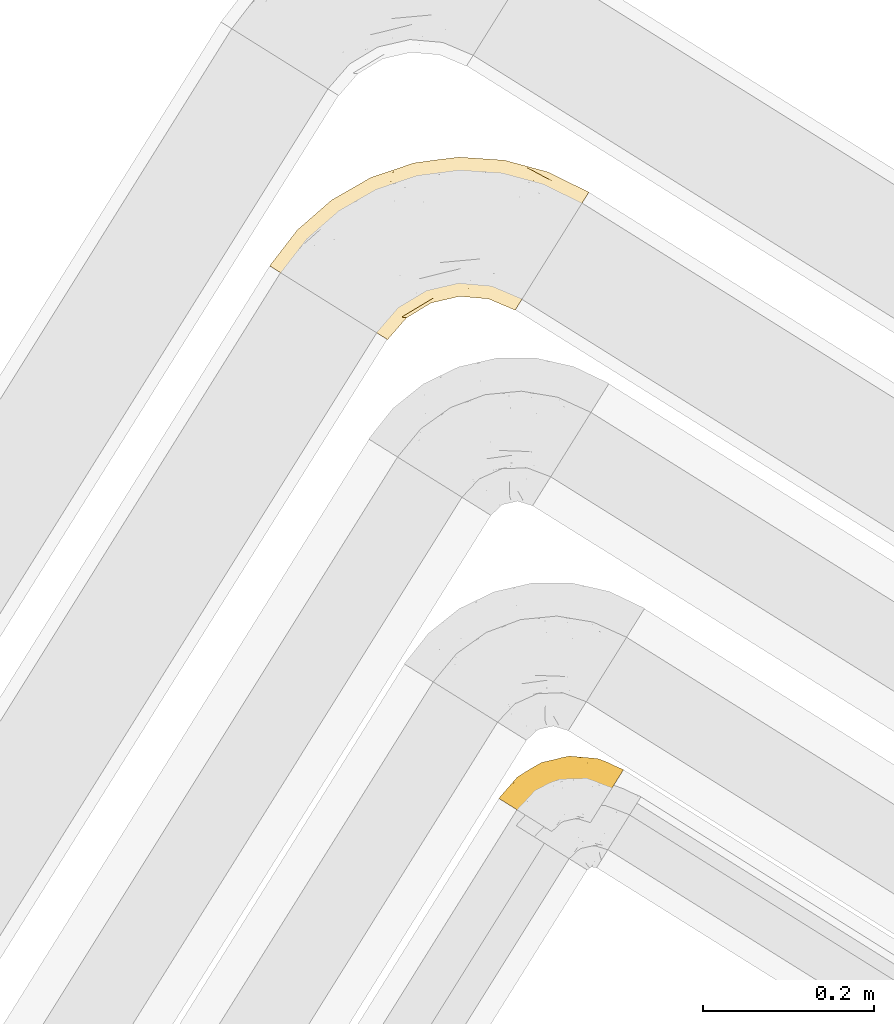
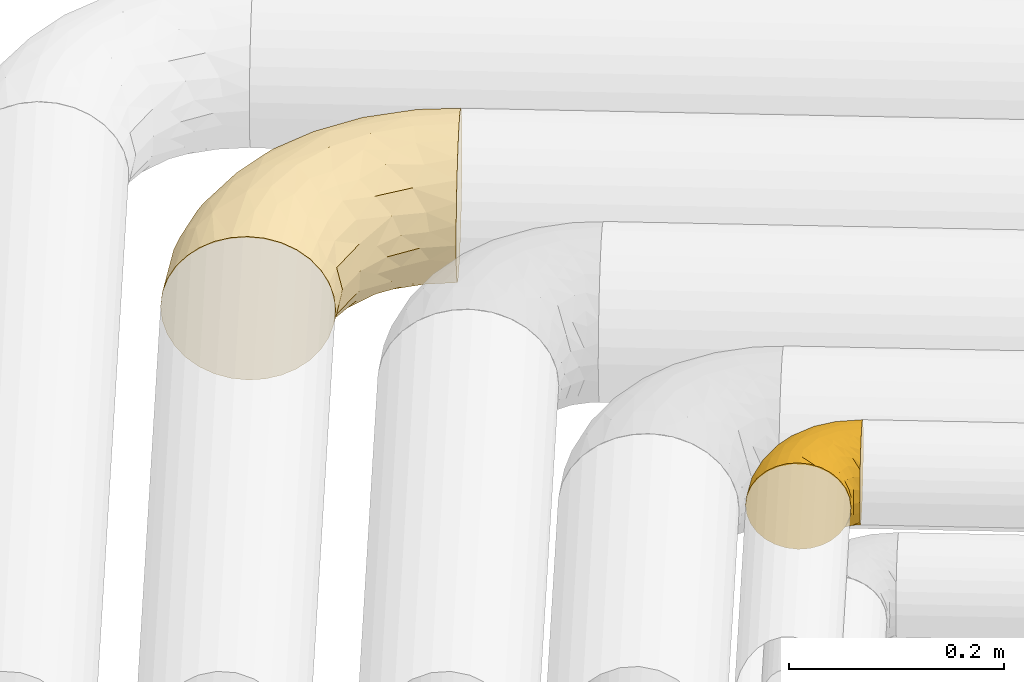
# One storey, part 25 of 93: 2 coverings.
"""IFC2X3 building model written with IfcOpenShell, lengths in millimetres."""

from ifc_helpers import new_model, entity, si_unit, converted_unit, derived_unit, direction, frame, origin, place, context, subcontext, project, spatial, faceted_brep, element, save


model = new_model("IFC2X3")

# Units and contexts
model_context = context("Model", 3, precision=0.01, world=origin(), true_north=direction((6.12303176911189e-17, 1.0)))
body_context = subcontext(model_context, "Body", "Model", "MODEL_VIEW")
ifc_project = project(units=[si_unit("LENGTHUNIT", "METRE", prefix="MILLI"), si_unit("AREAUNIT", "SQUARE_METRE"), si_unit("VOLUMEUNIT", "CUBIC_METRE"), converted_unit("PLANEANGLEUNIT", "DEGREE", entity("IfcRatioMeasure", 0.0174532925199433), si_unit("PLANEANGLEUNIT", "RADIAN"), dimensions=[0, 0, 0, 0, 0, 0, 0]), si_unit("MASSUNIT", "GRAM", prefix="KILO"), derived_unit("MASSDENSITYUNIT", [(si_unit("MASSUNIT", "GRAM", prefix="KILO"), 1), (si_unit("LENGTHUNIT", "METRE"), -3)]), derived_unit("MOMENTOFINERTIAUNIT", [(si_unit("LENGTHUNIT", "METRE"), 4)]), si_unit("TIMEUNIT", "SECOND"), si_unit("FREQUENCYUNIT", "HERTZ"), si_unit("THERMODYNAMICTEMPERATUREUNIT", "DEGREE_CELSIUS"), derived_unit("THERMALTRANSMITTANCEUNIT", [(si_unit("MASSUNIT", "GRAM", prefix="KILO"), 1), (si_unit("THERMODYNAMICTEMPERATUREUNIT", "KELVIN"), -1), (si_unit("TIMEUNIT", "SECOND"), -3)]), derived_unit("VOLUMETRICFLOWRATEUNIT", [(si_unit("LENGTHUNIT", "METRE"), 3), (si_unit("TIMEUNIT", "SECOND"), -1)]), derived_unit("MASSFLOWRATEUNIT", [(si_unit("MASSUNIT", "GRAM", prefix="KILO"), 1), (si_unit("TIMEUNIT", "SECOND"), -1)]), derived_unit("ROTATIONALFREQUENCYUNIT", [(si_unit("TIMEUNIT", "SECOND"), -1)]), si_unit("ELECTRICCURRENTUNIT", "AMPERE"), si_unit("ELECTRICVOLTAGEUNIT", "VOLT"), si_unit("POWERUNIT", "WATT"), si_unit("FORCEUNIT", "NEWTON", prefix="KILO"), si_unit("ILLUMINANCEUNIT", "LUX"), si_unit("LUMINOUSFLUXUNIT", "LUMEN"), si_unit("LUMINOUSINTENSITYUNIT", "CANDELA"), derived_unit("USERDEFINED", [(si_unit("MASSUNIT", "GRAM", prefix="KILO"), -1), (si_unit("LENGTHUNIT", "METRE"), -2), (si_unit("TIMEUNIT", "SECOND"), 3), (si_unit("LUMINOUSFLUXUNIT", "LUMEN"), 1)]), derived_unit("LINEARVELOCITYUNIT", [(si_unit("LENGTHUNIT", "METRE"), 1), (si_unit("TIMEUNIT", "SECOND"), -1)]), si_unit("PRESSUREUNIT", "PASCAL"), derived_unit("USERDEFINED", [(si_unit("LENGTHUNIT", "METRE"), -2), (si_unit("MASSUNIT", "GRAM", prefix="KILO"), 1), (si_unit("TIMEUNIT", "SECOND"), -2)]), derived_unit("LINEARFORCEUNIT", [(si_unit("MASSUNIT", "GRAM", prefix="KILO"), 1), (si_unit("LENGTHUNIT", "METRE"), 1), (si_unit("TIMEUNIT", "SECOND"), -2), (si_unit("LENGTHUNIT", "METRE"), -1)]), derived_unit("PLANARFORCEUNIT", [(si_unit("MASSUNIT", "GRAM", prefix="KILO"), 1), (si_unit("LENGTHUNIT", "METRE"), 1), (si_unit("TIMEUNIT", "SECOND"), -2), (si_unit("LENGTHUNIT", "METRE"), -2)])], contexts=[model_context])

# Site, building, storey
site_placement = place(None, origin())
site = spatial("IfcSite", under=ifc_project, at=site_placement, CompositionType="ELEMENT")
building_placement = place(site_placement, origin())
building = spatial("IfcBuilding", under=site, at=building_placement, CompositionType="ELEMENT")
storey_placement = place(building_placement, frame((0.0, 0.0, -4200.0)))
storey = spatial("IfcBuildingStorey", under=building, at=storey_placement, CompositionType="ELEMENT", Elevation=-4200.0)

# Coverings
covering_1_placement = place(storey_placement, frame((15873.6, 11387.06, 2916.9)))
element("IfcCovering", 1, at=covering_1_placement, inside=storey, Name=":ADSK_", ObjectType=":ADSK_", PredefinedType="INSULATION", context=body_context, shape_type="Brep", body=[
    faceted_brep([(44.26, 61.31, 158.39), (32.31, 68.78, 150.86), (21.84, 75.32, 140.72), (13.24, 80.69, 128.37), (6.86, 84.68, 114.28), (2.92, 87.14, 98.99), (1.6, 87.97, 83.1), (2.92, 87.14, 67.2), (6.86, 84.68, 51.91), (13.24, 80.69, 37.82), (21.84, 75.32, 25.47), (32.31, 68.78, 15.33), (44.26, 61.31, 7.8), (57.23, 53.21, 3.16), (70.71, 44.78, 1.6), (84.2, 36.36, 3.16), (97.16, 28.26, 7.8), (109.11, 20.79, 15.33), (119.58, 14.24, 25.47), (128.18, 8.87, 37.82), (134.57, 4.88, 51.91), (138.5, 2.43, 67.2), (139.83, 1.6, 83.1), (138.5, 2.43, 99.0), (134.57, 4.88, 114.28), (128.18, 8.87, 128.37), (119.58, 14.25, 140.72), (109.11, 20.79, 150.86), (97.16, 28.26, 158.39), (84.19, 36.36, 163.03), (70.71, 44.78, 164.6), (57.23, 53.21, 163.03), (290.81, 38.47, 62.0), (295.12, 45.37, 42.35), (301.99, 56.36, 25.47), (310.93, 70.67, 12.51), (321.35, 87.34, 4.37), (332.52, 105.23, 1.6), (343.7, 123.12, 4.37), (354.12, 139.79, 12.51), (363.06, 154.1, 25.47), (369.93, 165.08, 42.35), (374.24, 171.99, 62.0), (375.71, 174.34, 83.1), (374.24, 171.99, 104.19), (369.93, 165.08, 123.85), (363.06, 154.1, 140.72), (354.12, 139.79, 153.68), (343.7, 123.12, 161.82), (332.52, 105.23, 164.6), (321.35, 87.34, 161.82), (310.93, 70.67, 153.68), (301.99, 56.36, 140.72), (295.12, 45.37, 123.85), (290.81, 38.47, 104.19), (289.34, 36.11, 83.1), (303.99, 202.82, 104.67), (328.03, 197.99, 83.1), (276.65, 211.88, 83.1), (262.59, 196.89, 132.71), (202.71, 200.08, 128.57), (225.88, 192.07, 140.31), (143.86, 187.34, 127.0), (200.1, 208.43, 111.93), (145.82, 197.72, 107.33), (197.35, 212.28, 96.47), (69.76, 109.64, 153.13), (252.54, 206.3, 119.3), (247.03, 213.11, 101.32), (128.84, 166.78, 142.92), (85.14, 141.17, 142.61), (110.31, 143.75, 151.87), (294.95, 142.4, 162.56), (252.64, 132.96, 164.6), (294.15, 123.59, 164.6), (223.55, 215.47, 83.1), (82.79, 161.59, 117.97), (46.8, 130.78, 119.64), (84.59, 153.3, 131.15), (170.77, 208.64, 83.1), (120.33, 191.64, 83.1), (293.96, 160.74, 156.52), (274.17, 184.31, 144.21), (323.37, 167.6, 146.25), (311.25, 187.83, 130.43), (97.16, 78.11, 164.6), (108.65, 112.08, 162.51), (224.85, 161.05, 159.97), (217.01, 178.3, 151.26), (158.57, 167.13, 151.21), (329.49, 189.16, 117.68), (141.96, 146.57, 158.25), (152.15, 133.89, 163.04), (42.35, 134.23, 105.24), (83.84, 169.39, 100.78), (50.75, 106.99, 144.52), (176.4, 184.25, 141.87), (49.69, 122.0, 132.77), (74.18, 165.13, 83.1), (34.09, 130.13, 83.1), (130.35, 104.72, 164.6), (168.64, 123.28, 164.6), (210.1, 132.85, 164.6), (280.75, 80.9, 151.23), (261.7, 70.1, 137.69), (284.47, 102.8, 161.34), (164.81, 58.87, 141.27), (141.93, 38.59, 138.72), (163.98, 44.73, 127.05), (193.38, 50.32, 109.71), (162.1, 27.21, 83.1), (191.2, 44.7, 83.1), (235.46, 61.6, 120.43), (224.45, 74.35, 138.75), (196.71, 61.76, 129.2), (169.09, 101.3, 161.91), (144.64, 87.13, 161.43), (169.1, 84.21, 155.97), (235.91, 116.0, 162.57), (195.15, 103.02, 160.03), (216.01, 89.43, 151.82), (267.74, 54.35, 117.14), (156.27, 27.97, 109.48), (126.24, 38.95, 148.92), (143.8, 61.02, 151.93), (247.37, 94.66, 154.85), (267.44, 48.23, 98.92), (240.45, 54.25, 100.98), (224.27, 52.33, 83.1), (258.09, 49.38, 83.1), (189.58, 75.03, 145.5), (119.33, 55.41, 158.16), (121.71, 78.58, 162.97), (101.82, 57.56, 162.71), (213.63, 52.6, 98.76), (260.19, 105.07, 160.15), (144.74, 26.03, 124.12), (192.15, 88.67, 154.06), (247.38, 94.66, 11.34), (261.7, 70.1, 28.5), (224.45, 74.35, 27.44), (216.01, 89.42, 14.37), (267.44, 48.23, 67.27), (240.45, 54.25, 65.22), (163.98, 44.73, 39.14), (164.81, 58.88, 24.93), (196.71, 61.76, 36.99), (101.83, 57.56, 3.48), (193.38, 50.32, 56.48), (280.75, 80.9, 14.96), (284.47, 102.8, 4.85), (144.74, 26.03, 42.07), (141.93, 38.59, 27.47), (235.46, 61.6, 45.76), (213.63, 52.6, 67.43), (121.71, 78.58, 3.22), (119.33, 55.41, 8.03), (294.15, 123.59, 1.6), (267.74, 54.35, 49.05), (126.24, 38.95, 17.27), (156.27, 27.97, 56.71), (260.67, 116.21, 3.08), (235.91, 116.0, 3.62), (130.35, 104.72, 1.6), (168.64, 123.28, 1.6), (144.64, 87.13, 4.76), (210.1, 132.85, 1.6), (252.64, 132.96, 1.6), (189.59, 75.03, 20.69), (195.15, 103.02, 6.16), (143.8, 61.02, 14.26), (169.1, 84.21, 10.22), (169.09, 101.3, 4.28), (97.16, 78.11, 1.6), (192.03, 88.24, 12.35), (311.25, 187.83, 35.76), (85.14, 141.17, 23.58), (84.56, 153.27, 35.03), (125.1, 175.77, 34.03), (35.39, 118.57, 46.35), (268.93, 149.08, 3.68), (220.27, 149.61, 3.15), (223.86, 165.48, 7.94), (176.4, 184.25, 24.32), (180.5, 199.06, 41.48), (143.01, 142.16, 6.22), (109.58, 108.16, 2.91), (203.66, 209.98, 57.48), (281.97, 165.41, 10.43), (267.58, 195.86, 33.0), (274.17, 184.31, 21.98), (226.44, 194.19, 28.1), (296.9, 199.45, 47.91), (50.75, 106.99, 21.67), (145.82, 197.72, 58.86), (76.79, 118.16, 13.93), (252.54, 206.3, 46.89), (252.6, 212.26, 62.93), (323.37, 167.6, 19.94), (303.99, 202.82, 61.52), (126.98, 154.29, 15.08), (87.45, 107.86, 6.68), (83.84, 169.39, 65.41), (218.36, 180.9, 16.65), (174.99, 165.92, 11.53), (42.35, 134.23, 60.95), (49.69, 122.0, 33.42), (82.8, 161.59, 48.22)], [[[0, 1, 2, 3, 4, 5, 6, 7, 8, 9, 10, 11, 12, 13, 14, 15, 16, 17, 18, 19, 20, 21, 22, 23, 24, 25, 26, 27, 28, 29, 30, 31]], [[32, 33, 34, 35, 36, 37, 38, 39, 40, 41, 42, 43, 44, 45, 46, 47, 48, 49, 50, 51, 52, 53, 54, 55]], [[56, 57, 58]], [[57, 44, 43]], [[59, 60, 61]], [[62, 63, 64]], [[63, 65, 64]], [[1, 0, 66]], [[67, 68, 63]], [[69, 70, 71]], [[72, 73, 74]], [[75, 68, 58]], [[76, 77, 78]], [[64, 79, 80]], [[81, 48, 47]], [[82, 83, 84]], [[31, 85, 86]], [[71, 70, 66]], [[47, 83, 81]], [[87, 88, 89]], [[69, 62, 78]], [[49, 48, 72]], [[90, 44, 56]], [[48, 81, 72]], [[87, 91, 92]], [[93, 76, 94]], [[70, 95, 66]], [[88, 96, 89]], [[45, 84, 46]], [[2, 95, 97]], [[4, 93, 5]], [[98, 99, 93]], [[59, 84, 67]], [[3, 97, 77]], [[71, 86, 91]], [[4, 3, 77]], [[90, 84, 45]], [[99, 6, 5]], [[83, 47, 46]], [[95, 2, 1]], [[94, 80, 98]], [[100, 101, 92]], [[66, 31, 86]], [[60, 63, 62]], [[85, 31, 30]], [[102, 87, 92]], [[93, 77, 76]], [[91, 86, 92]], [[44, 57, 56]], [[86, 85, 100]], [[78, 97, 70]], [[87, 102, 73]], [[2, 97, 3]], [[67, 84, 90]], [[31, 66, 0]], [[93, 94, 98]], [[88, 81, 82]], [[99, 5, 93]], [[87, 73, 72]], [[66, 95, 1]], [[97, 95, 70]], [[86, 71, 66]], [[69, 89, 96]], [[89, 71, 91]], [[69, 96, 62]], [[60, 62, 96]], [[76, 62, 64]], [[71, 89, 69]], [[87, 89, 91]], [[81, 88, 87]], [[61, 88, 82]], [[61, 60, 96]], [[60, 67, 63]], [[68, 67, 56]], [[79, 65, 75]], [[58, 68, 56]], [[65, 68, 75]], [[64, 65, 79]], [[68, 65, 63]], [[76, 64, 94]], [[80, 94, 64]], [[100, 92, 86]], [[92, 101, 102]], [[88, 61, 96]], [[59, 61, 82]], [[84, 59, 82]], [[60, 59, 67]], [[87, 72, 81]], [[49, 72, 74]], [[84, 83, 46]], [[81, 83, 82]], [[69, 78, 70]], [[62, 76, 78]], [[4, 77, 93]], [[78, 77, 97]], [[44, 90, 45]], [[67, 90, 56]], [[103, 104, 52]], [[50, 49, 74]], [[50, 74, 105]], [[106, 107, 108]], [[109, 110, 111]], [[112, 113, 114]], [[104, 113, 112]], [[73, 105, 74]], [[115, 116, 117]], [[118, 119, 120]], [[104, 53, 52]], [[51, 103, 52]], [[53, 121, 54]], [[24, 23, 122]], [[123, 107, 124]], [[122, 109, 108]], [[125, 120, 113]], [[55, 54, 126]], [[102, 118, 73]], [[127, 126, 121]], [[128, 129, 127]], [[105, 51, 50]], [[102, 101, 119]], [[120, 130, 113]], [[26, 123, 27]], [[27, 131, 28]], [[132, 85, 133]], [[85, 29, 133]], [[134, 111, 128]], [[28, 133, 29]], [[30, 29, 85]], [[116, 131, 124]], [[135, 73, 118]], [[27, 123, 131]], [[110, 23, 22]], [[136, 122, 108]], [[24, 136, 25]], [[114, 108, 109]], [[119, 115, 117]], [[136, 107, 25]], [[128, 127, 134]], [[122, 110, 109]], [[104, 112, 121]], [[107, 106, 124]], [[107, 26, 25]], [[23, 110, 122]], [[101, 100, 116]], [[131, 132, 133]], [[105, 135, 103]], [[116, 124, 117]], [[122, 136, 24]], [[107, 136, 108]], [[28, 131, 133]], [[131, 116, 132]], [[126, 127, 129]], [[134, 112, 109]], [[107, 123, 26]], [[131, 123, 124]], [[104, 121, 53]], [[127, 121, 112]], [[105, 103, 51]], [[104, 103, 125]], [[116, 100, 132]], [[85, 132, 100]], [[106, 117, 124]], [[137, 130, 120]], [[114, 106, 108]], [[106, 130, 117]], [[119, 118, 102]], [[135, 118, 125]], [[125, 113, 104]], [[114, 113, 130]], [[114, 130, 106]], [[112, 114, 109]], [[118, 120, 125]], [[117, 137, 119]], [[55, 126, 129]], [[121, 126, 54]], [[112, 134, 127]], [[111, 134, 109]], [[119, 101, 115]], [[101, 116, 115]], [[103, 135, 125]], [[73, 135, 105]], [[130, 137, 117]], [[120, 119, 137]], [[138, 139, 140]], [[140, 141, 138]], [[55, 129, 142]], [[143, 142, 129]], [[144, 145, 146]], [[147, 16, 15]], [[110, 148, 111]], [[128, 143, 129]], [[149, 150, 35]], [[151, 152, 144]], [[153, 143, 154]], [[147, 155, 156]], [[35, 150, 36]], [[37, 36, 157]], [[35, 34, 149]], [[139, 33, 158]], [[159, 152, 18]], [[150, 157, 36]], [[140, 139, 153]], [[139, 34, 33]], [[110, 21, 160]], [[150, 161, 157]], [[20, 19, 151]], [[161, 138, 162]], [[110, 22, 21]], [[163, 164, 165]], [[166, 167, 162]], [[151, 160, 20]], [[140, 146, 168]], [[111, 148, 154]], [[164, 166, 169]], [[18, 152, 19]], [[170, 156, 165]], [[17, 159, 18]], [[158, 33, 32]], [[171, 165, 172]], [[155, 165, 156]], [[148, 110, 160]], [[170, 159, 156]], [[160, 144, 148]], [[15, 14, 173]], [[170, 171, 145]], [[149, 139, 138]], [[15, 173, 147]], [[144, 152, 145]], [[156, 17, 16]], [[165, 171, 170]], [[20, 160, 21]], [[171, 172, 169]], [[169, 166, 162]], [[152, 151, 19]], [[160, 151, 144]], [[155, 173, 163]], [[156, 16, 147]], [[154, 143, 128]], [[143, 153, 158]], [[156, 159, 17]], [[152, 159, 170]], [[158, 32, 142]], [[139, 158, 153]], [[139, 149, 34]], [[150, 149, 138]], [[173, 155, 147]], [[163, 165, 155]], [[174, 169, 141]], [[145, 171, 168]], [[170, 145, 152]], [[146, 145, 168]], [[161, 162, 167]], [[162, 138, 141]], [[146, 153, 148]], [[140, 168, 141]], [[153, 146, 140]], [[144, 146, 148]], [[174, 141, 168]], [[162, 141, 169]], [[158, 142, 143]], [[55, 142, 32]], [[111, 154, 128]], [[153, 154, 148]], [[165, 164, 172]], [[164, 169, 172]], [[157, 161, 167]], [[138, 161, 150]], [[168, 171, 174]], [[169, 174, 171]], [[41, 40, 175]], [[176, 177, 178]], [[9, 8, 179]], [[180, 181, 182]], [[157, 180, 37]], [[183, 178, 184]], [[164, 185, 181]], [[13, 186, 173]], [[187, 79, 75]], [[167, 166, 181]], [[186, 163, 173]], [[182, 188, 180]], [[57, 43, 42]], [[189, 190, 191]], [[164, 186, 185]], [[192, 41, 175]], [[193, 11, 10]], [[178, 194, 184]], [[12, 11, 195]], [[196, 187, 197]], [[40, 198, 175]], [[198, 40, 39]], [[58, 199, 197]], [[200, 185, 201]], [[163, 186, 164]], [[201, 185, 186]], [[202, 80, 194]], [[190, 203, 191]], [[201, 186, 13]], [[204, 185, 200]], [[201, 13, 12]], [[41, 199, 42]], [[195, 200, 201]], [[98, 205, 99]], [[57, 42, 199]], [[13, 173, 14]], [[58, 57, 199]], [[193, 206, 176]], [[80, 79, 194]], [[207, 205, 202]], [[196, 184, 187]], [[202, 205, 98]], [[205, 179, 8]], [[9, 206, 10]], [[207, 206, 179]], [[182, 203, 188]], [[6, 99, 7]], [[188, 38, 180]], [[203, 182, 204]], [[7, 205, 8]], [[37, 180, 38]], [[167, 180, 157]], [[7, 99, 205]], [[182, 181, 185]], [[11, 193, 195]], [[196, 191, 184]], [[175, 189, 192]], [[198, 188, 190]], [[38, 188, 39]], [[206, 193, 10]], [[195, 193, 176]], [[195, 176, 200]], [[12, 195, 201]], [[178, 200, 176]], [[185, 204, 182]], [[200, 183, 204]], [[203, 204, 183]], [[191, 203, 183]], [[188, 203, 190]], [[184, 191, 183]], [[190, 189, 175]], [[200, 178, 183]], [[184, 194, 187]], [[177, 176, 206]], [[194, 178, 207]], [[79, 187, 194]], [[197, 199, 192]], [[187, 75, 197]], [[58, 197, 75]], [[191, 196, 189]], [[192, 189, 196]], [[80, 202, 98]], [[194, 207, 202]], [[167, 181, 180]], [[181, 166, 164]], [[188, 198, 39]], [[175, 198, 190]], [[207, 179, 205]], [[9, 179, 206]], [[197, 192, 196]], [[41, 192, 199]], [[206, 207, 177]], [[207, 178, 177]]]),
])
covering_2_placement = place(storey_placement, frame((16142.14, 10797.23, 3008.06)))
element("IfcCovering", 2, at=covering_2_placement, inside=storey, Name=":ADSK_", ObjectType=":ADSK_", PredefinedType="INSULATION", context=body_context, shape_type="Brep", body=[
    faceted_brep([(43.28, 27.64, 99.9), (34.0, 33.44, 98.66), (25.19, 38.95, 95.02), (17.28, 43.88, 89.17), (10.68, 48.01, 81.38), (5.72, 51.11, 72.06), (2.64, 53.03, 61.68), (1.6, 53.69, 50.75), (2.64, 53.03, 39.8), (5.73, 51.11, 29.41), (10.69, 48.0, 20.09), (17.29, 43.88, 12.31), (25.2, 38.94, 6.46), (34.01, 33.43, 2.83), (43.28, 27.64, 1.6), (48.11, 24.62, 2.24), (52.56, 21.84, 2.83), (56.96, 19.09, 4.65), (61.37, 16.34, 6.47), (69.27, 11.4, 12.32), (75.87, 7.27, 20.11), (80.83, 4.17, 29.43), (83.91, 2.25, 39.81), (84.96, 1.6, 50.75), (83.91, 2.25, 61.69), (80.83, 4.18, 72.08), (75.86, 7.28, 81.4), (69.26, 11.41, 89.18), (61.36, 16.34, 95.03), (56.95, 19.1, 96.85), (52.55, 21.85, 98.66), (48.11, 24.62, 99.25), (45.69, 26.13, 99.57), (96.66, 5.51, 38.02), (99.26, 9.68, 26.17), (101.33, 12.99, 21.08), (103.4, 16.3, 15.99), (106.1, 20.62, 12.09), (108.8, 24.93, 8.18), (111.94, 29.96, 5.73), (115.08, 34.99, 3.27), (118.78, 40.91, 2.35), (120.3, 43.34, 1.97), (121.82, 45.77, 1.6), (128.56, 56.56, 3.27), (134.84, 66.61, 8.18), (140.24, 75.25, 15.99), (144.38, 81.87, 26.17), (146.98, 86.04, 38.02), (147.87, 87.46, 50.75), (146.98, 86.04, 63.47), (144.38, 81.87, 75.32), (140.24, 75.25, 85.5), (134.84, 66.61, 93.31), (128.56, 56.56, 98.22), (121.82, 45.77, 99.9), (118.78, 40.91, 99.14), (115.08, 34.99, 98.22), (111.94, 29.96, 95.77), (108.8, 24.93, 93.31), (106.1, 20.62, 89.4), (103.4, 16.3, 85.5), (101.33, 12.99, 80.41), (99.26, 9.68, 75.32), (96.66, 5.51, 63.47), (95.78, 4.09, 50.75), (76.15, 101.69, 59.31), (86.12, 98.07, 73.08), (97.37, 101.68, 63.72), (117.3, 100.43, 50.75), (127.85, 96.53, 58.64), (136.6, 92.24, 50.75), (105.59, 95.16, 76.74), (123.77, 95.43, 67.68), (126.45, 88.25, 78.92), (51.16, 66.17, 94.31), (48.0, 48.95, 98.76), (65.59, 61.39, 98.4), (113.14, 73.71, 94.57), (92.83, 84.12, 89.91), (85.54, 72.58, 96.32), (109.18, 62.49, 98.79), (101.02, 53.65, 99.9), (106.25, 51.67, 99.9), (111.49, 49.69, 99.9), (114.07, 48.71, 99.9), (116.65, 47.73, 99.9), (115.97, 83.91, 87.31), (37.46, 52.28, 95.61), (37.0, 87.33, 60.43), (19.1, 71.93, 65.24), (36.96, 82.24, 72.87), (58.52, 43.84, 99.9), (63.58, 46.12, 99.9), (68.65, 48.41, 99.9), (73.72, 50.69, 99.9), (78.79, 52.97, 99.9), (30.82, 57.84, 90.65), (52.79, 94.52, 63.14), (74.56, 79.56, 91.89), (18.31, 64.87, 75.25), (9.62, 62.92, 50.75), (89.52, 92.19, 82.18), (70.56, 87.16, 85.08), (69.09, 93.42, 76.93), (51.85, 95.86, 50.75), (68.03, 99.59, 50.75), (28.09, 66.81, 83.02), (45.17, 29.65, 99.9), (47.06, 31.67, 99.9), (50.85, 35.69, 99.9), (54.68, 39.77, 99.9), (46.17, 75.16, 87.13), (53.78, 85.5, 80.85), (87.81, 62.75, 99.17), (23.38, 78.75, 50.75), (84.35, 53.14, 99.9), (89.91, 53.31, 99.9), (95.47, 53.48, 99.9), (84.21, 103.33, 50.75), (68.41, 97.96, 67.61), (53.46, 91.16, 72.25), (37.62, 87.3, 50.75), (100.75, 101.88, 50.75), (57.74, 28.83, 98.69), (110.54, 41.26, 99.01), (100.55, 43.22, 98.79), (106.06, 39.57, 98.29), (85.4, 6.72, 68.51), (82.87, 10.04, 76.82), (67.53, 36.06, 98.54), (62.5, 37.29, 99.3), (96.52, 17.26, 83.57), (98.68, 23.22, 89.47), (93.22, 12.04, 75.76), (91.2, 19.05, 84.86), (86.86, 11.41, 75.89), (90.98, 7.31, 64.77), (82.81, 24.61, 90.83), (77.49, 29.29, 94.62), (77.11, 21.29, 90.37), (102.39, 24.43, 91.18), (100.73, 33.08, 95.55), (73.99, 16.15, 88.65), (79.77, 14.66, 84.11), (87.63, 27.07, 91.75), (64.27, 26.64, 96.86), (89.85, 5.08, 50.75), (87.07, 4.67, 58.97), (73.38, 38.42, 98.37), (84.01, 16.72, 83.91), (81.43, 38.09, 97.52), (95.38, 43.77, 98.76), (95.28, 33.4, 95.26), (88.08, 40.92, 98.04), (93.2, 25.7, 90.65), (69.26, 21.4, 93.51), (73.01, 25.85, 94.16), (90.72, 45.63, 99.1), (93.22, 12.04, 25.73), (93.21, 25.69, 10.84), (96.53, 17.26, 17.92), (91.22, 19.04, 16.64), (84.03, 7.04, 30.44), (67.53, 36.07, 2.95), (62.5, 37.28, 2.19), (63.58, 46.12, 1.6), (64.29, 26.63, 4.63), (79.78, 14.66, 17.39), (119.24, 46.75, 1.6), (111.49, 49.69, 1.6), (116.65, 47.73, 1.6), (74.01, 16.14, 12.86), (77.13, 21.29, 11.13), (106.06, 39.57, 3.2), (100.73, 33.08, 5.94), (98.68, 23.22, 12.02), (95.28, 33.4, 6.23), (102.39, 24.43, 10.31), (69.29, 21.37, 8.0), (73.02, 25.84, 7.34), (110.54, 41.26, 2.48), (95.38, 43.77, 2.73), (100.49, 43.51, 2.64), (50.85, 35.69, 1.6), (57.75, 28.84, 2.8), (90.99, 7.31, 36.71), (106.25, 51.67, 1.6), (101.02, 53.65, 1.6), (86.97, 5.58, 38.59), (47.06, 31.67, 1.6), (48.96, 33.68, 1.6), (68.65, 48.41, 1.6), (73.38, 38.41, 3.12), (84.02, 16.71, 17.59), (73.72, 50.69, 1.6), (81.46, 38.06, 3.98), (77.5, 29.3, 6.87), (88.08, 40.91, 3.45), (87.65, 27.04, 9.76), (54.68, 39.77, 1.6), (58.52, 43.84, 1.6), (86.87, 11.41, 25.62), (82.83, 24.6, 10.67), (90.72, 45.63, 2.39), (89.91, 53.31, 1.6), (95.47, 53.48, 1.6), (84.35, 53.14, 1.6), (78.79, 52.97, 1.6), (87.71, 63.16, 2.4), (127.85, 96.53, 42.85), (115.97, 83.91, 14.18), (93.19, 84.09, 11.56), (89.56, 92.17, 19.27), (105.59, 95.16, 24.75), (86.07, 98.05, 28.37), (37.16, 52.18, 5.95), (47.91, 49.24, 2.79), (109.18, 62.49, 2.71), (97.37, 101.68, 37.78), (123.77, 95.43, 33.81), (126.45, 88.26, 22.57), (113.14, 73.71, 6.92), (36.96, 82.23, 28.61), (19.1, 71.93, 36.24), (37.01, 87.34, 41.05), (69.0, 93.4, 24.55), (68.41, 97.96, 33.88), (50.66, 65.72, 7.11), (52.83, 94.55, 38.38), (76.15, 101.69, 42.18), (28.1, 66.81, 18.46), (30.83, 57.83, 10.84), (53.65, 85.49, 20.69), (53.43, 91.17, 29.27), (65.59, 61.42, 3.1), (68.34, 77.34, 9.18), (18.32, 64.87, 26.23), (46.34, 75.25, 14.34), (85.39, 73.28, 5.46), (70.56, 87.15, 16.39)], [[[0, 1, 2, 3, 4, 5, 6, 7, 8, 9, 10, 11, 12, 13, 14, 15, 16, 17, 18, 19, 20, 21, 22, 23, 24, 25, 26, 27, 28, 29, 30, 31, 32]], [[33, 34, 35, 36, 37, 38, 39, 40, 41, 42, 43, 44, 45, 46, 47, 48, 49, 50, 51, 52, 53, 54, 55, 56, 57, 58, 59, 60, 61, 62, 63, 64, 65]], [[66, 67, 68]], [[69, 70, 71]], [[68, 72, 73]], [[73, 72, 74]], [[75, 76, 77]], [[78, 79, 80]], [[51, 50, 73]], [[81, 82, 83, 84, 85, 86, 55]], [[52, 87, 53]], [[74, 52, 51]], [[2, 1, 88]], [[89, 90, 91]], [[77, 92, 93, 94, 95, 96]], [[55, 54, 81]], [[78, 53, 87]], [[5, 90, 6]], [[88, 76, 75]], [[97, 3, 2]], [[89, 91, 98]], [[99, 80, 79]], [[90, 5, 100]], [[74, 87, 52]], [[100, 5, 4]], [[90, 101, 6]], [[79, 102, 103]], [[102, 67, 104]], [[105, 98, 106]], [[107, 4, 3]], [[76, 0, 108, 109, 110, 111, 92]], [[107, 112, 113]], [[114, 77, 96]], [[89, 115, 90]], [[114, 96, 116, 117, 118, 82]], [[75, 97, 88]], [[119, 66, 68]], [[50, 71, 70]], [[100, 91, 90]], [[99, 77, 80]], [[102, 104, 103]], [[97, 107, 3]], [[80, 81, 78]], [[107, 97, 112]], [[68, 73, 70]], [[66, 98, 120]], [[78, 81, 54]], [[114, 81, 80]], [[53, 78, 54]], [[78, 87, 79]], [[102, 87, 72]], [[79, 103, 99]], [[4, 107, 100]], [[91, 100, 107]], [[88, 97, 2]], [[112, 97, 75]], [[99, 112, 75]], [[103, 104, 113]], [[91, 121, 98]], [[89, 105, 122, 115]], [[101, 90, 115]], [[101, 7, 6]], [[88, 1, 76]], [[0, 76, 1]], [[92, 77, 76]], [[73, 74, 51]], [[87, 74, 72]], [[81, 114, 82]], [[77, 114, 80]], [[87, 102, 79]], [[67, 102, 72]], [[68, 67, 72]], [[67, 120, 104]], [[120, 121, 104]], [[104, 121, 113]], [[121, 120, 98]], [[91, 107, 113]], [[91, 113, 121]], [[103, 113, 112]], [[66, 119, 106]], [[105, 89, 98]], [[68, 69, 123, 119]], [[98, 66, 106]], [[66, 120, 67]], [[50, 49, 71]], [[50, 70, 73]], [[112, 99, 103]], [[77, 99, 75]], [[69, 68, 70]], [[29, 124, 110]], [[84, 83, 125]], [[126, 82, 118]], [[59, 58, 127]], [[25, 128, 129]], [[130, 93, 131]], [[132, 62, 133]], [[134, 135, 136]], [[137, 65, 64]], [[64, 134, 137]], [[138, 139, 140]], [[111, 110, 124, 92]], [[134, 136, 137]], [[134, 64, 63]], [[141, 60, 142]], [[125, 58, 57]], [[143, 144, 140]], [[143, 26, 144]], [[127, 83, 82]], [[28, 124, 29]], [[32, 31, 30, 110, 109, 108, 0]], [[30, 29, 110]], [[135, 145, 138]], [[28, 146, 124]], [[57, 56, 55, 86, 85, 84]], [[147, 148, 23]], [[24, 23, 148]], [[25, 144, 26]], [[95, 94, 149]], [[24, 128, 25]], [[150, 138, 144]], [[124, 146, 131]], [[127, 58, 125]], [[151, 149, 139]], [[127, 126, 142]], [[142, 59, 127]], [[152, 142, 126]], [[153, 154, 155]], [[153, 133, 141]], [[146, 28, 27]], [[143, 156, 27]], [[157, 149, 130]], [[61, 133, 62]], [[134, 132, 135]], [[148, 128, 24]], [[65, 137, 147]], [[147, 137, 148]], [[128, 137, 136]], [[137, 128, 148]], [[128, 136, 129]], [[150, 129, 136]], [[25, 129, 144]], [[158, 152, 117]], [[152, 118, 117]], [[153, 142, 152]], [[158, 116, 154]], [[145, 151, 138]], [[153, 152, 158]], [[133, 153, 155]], [[133, 155, 132]], [[153, 141, 142]], [[135, 132, 155]], [[134, 63, 132]], [[145, 135, 155]], [[135, 138, 150]], [[155, 154, 145]], [[151, 154, 96]], [[154, 151, 145]], [[149, 94, 130]], [[82, 126, 127]], [[118, 152, 126]], [[151, 96, 95]], [[139, 149, 157]], [[151, 95, 149]], [[93, 92, 131]], [[130, 146, 156]], [[130, 94, 93]], [[84, 125, 57]], [[127, 125, 83]], [[140, 139, 157]], [[151, 139, 138]], [[140, 157, 143]], [[138, 140, 144]], [[156, 143, 157]], [[27, 26, 143]], [[130, 156, 157]], [[146, 27, 156]], [[132, 63, 62]], [[124, 131, 92]], [[130, 131, 146]], [[129, 150, 144]], [[135, 150, 136]], [[60, 141, 61]], [[60, 59, 142]], [[133, 61, 141]], [[116, 96, 154]], [[153, 158, 154]], [[158, 117, 116]], [[34, 33, 159]], [[160, 161, 162]], [[22, 21, 163]], [[164, 165, 166]], [[19, 18, 167]], [[168, 21, 20]], [[169, 43, 42, 41, 40, 170, 171]], [[172, 173, 168]], [[174, 38, 175]], [[176, 177, 178]], [[179, 164, 180]], [[40, 181, 170]], [[182, 183, 175]], [[17, 184, 185]], [[65, 147, 186]], [[187, 174, 188]], [[23, 22, 189]], [[174, 39, 38]], [[15, 14, 190, 191, 184, 16]], [[181, 40, 39]], [[192, 193, 164]], [[194, 163, 168]], [[33, 186, 159]], [[180, 173, 172]], [[195, 196, 193]], [[18, 185, 167]], [[173, 180, 197]], [[198, 199, 196]], [[200, 201, 185, 184]], [[184, 17, 16]], [[18, 17, 185]], [[202, 159, 186]], [[194, 168, 203]], [[189, 163, 202]], [[204, 205, 182]], [[187, 181, 174]], [[160, 177, 176]], [[206, 183, 182]], [[206, 182, 205]], [[201, 165, 185]], [[165, 164, 167]], [[172, 179, 180]], [[202, 194, 162]], [[176, 161, 160]], [[65, 186, 33]], [[163, 189, 22]], [[175, 177, 182]], [[174, 183, 188]], [[177, 198, 204]], [[199, 160, 162]], [[198, 207, 204]], [[175, 38, 37]], [[198, 177, 160]], [[178, 177, 175]], [[176, 35, 161]], [[34, 159, 161]], [[162, 161, 159]], [[202, 162, 159]], [[199, 162, 203]], [[196, 199, 203]], [[198, 160, 199]], [[193, 197, 180]], [[208, 198, 196]], [[188, 183, 206]], [[175, 183, 174]], [[193, 192, 195]], [[195, 208, 196]], [[197, 196, 203]], [[180, 164, 193]], [[168, 163, 21]], [[166, 165, 201]], [[166, 192, 164]], [[189, 202, 186]], [[186, 147, 189]], [[23, 189, 147]], [[174, 181, 39]], [[170, 181, 187]], [[196, 197, 193]], [[173, 203, 168]], [[203, 173, 197]], [[172, 168, 20]], [[20, 19, 172]], [[179, 172, 19]], [[19, 167, 179]], [[164, 179, 167]], [[35, 176, 36]], [[35, 34, 161]], [[185, 165, 167]], [[162, 194, 203]], [[163, 194, 202]], [[176, 178, 36]], [[37, 36, 178]], [[175, 37, 178]], [[177, 204, 182]], [[207, 198, 208]], [[207, 205, 204]], [[209, 188, 206, 205, 207, 208]], [[48, 210, 71]], [[211, 212, 213]], [[214, 213, 215]], [[216, 217, 13]], [[218, 43, 169, 171, 170, 187, 188]], [[219, 220, 214]], [[47, 46, 221]], [[210, 48, 220]], [[211, 222, 212]], [[222, 45, 44]], [[221, 220, 47]], [[47, 220, 48]], [[221, 211, 214]], [[223, 224, 225]], [[211, 46, 45]], [[226, 227, 215]], [[43, 218, 44]], [[217, 216, 228]], [[227, 229, 230]], [[14, 13, 217]], [[224, 9, 8]], [[10, 231, 11]], [[11, 232, 12]], [[233, 223, 234]], [[235, 208, 195, 192, 166, 201]], [[236, 235, 228]], [[222, 44, 218]], [[106, 230, 229]], [[224, 237, 9]], [[232, 238, 228]], [[9, 237, 10]], [[115, 224, 101]], [[239, 235, 236]], [[232, 11, 231]], [[223, 231, 237]], [[224, 8, 101]], [[223, 229, 234]], [[225, 115, 122, 105]], [[216, 12, 232]], [[209, 235, 239]], [[210, 219, 69]], [[219, 214, 215]], [[230, 119, 219]], [[209, 218, 188]], [[239, 212, 222]], [[239, 222, 218]], [[45, 222, 211]], [[236, 212, 239]], [[213, 212, 240]], [[223, 237, 224]], [[231, 10, 237]], [[238, 232, 231]], [[216, 232, 228]], [[233, 231, 223]], [[236, 238, 240]], [[115, 225, 224]], [[234, 229, 227]], [[8, 7, 101]], [[235, 209, 208]], [[218, 209, 239]], [[217, 228, 235]], [[13, 12, 216]], [[235, 201, 217]], [[217, 201, 200, 184, 191, 190, 14]], [[211, 221, 46]], [[220, 221, 214]], [[71, 210, 69]], [[71, 49, 48]], [[219, 210, 220]], [[226, 215, 213]], [[211, 213, 214]], [[226, 213, 240]], [[215, 227, 230]], [[233, 240, 238]], [[234, 227, 226]], [[233, 234, 226]], [[229, 223, 225]], [[240, 233, 226]], [[233, 238, 231]], [[225, 105, 229]], [[229, 105, 106]], [[106, 119, 230]], [[123, 69, 219, 119]], [[215, 230, 219]], [[238, 236, 228]], [[212, 236, 240]]]),
])

save(model, "model.ifc")
